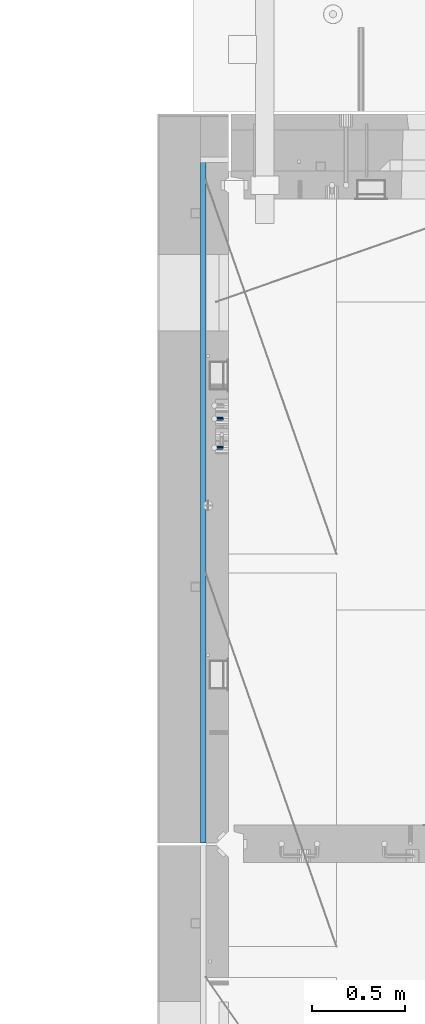
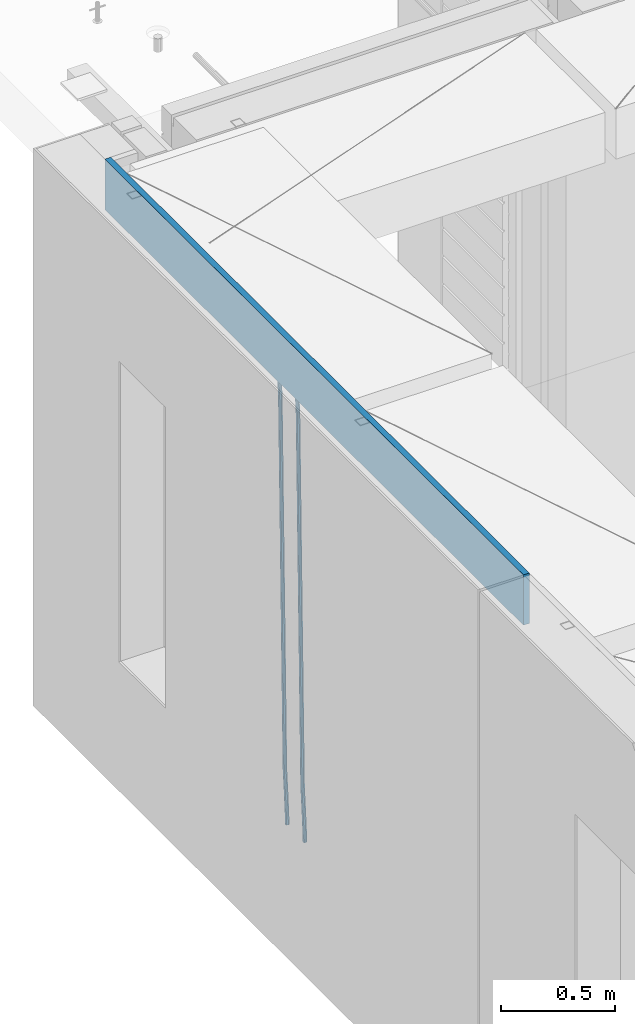
# One storey, part 96 of 309: 3 beams, 1 element without a shape of its own.
"""IFC2X3 building model written with IfcOpenShell, lengths in millimetres."""

from ifc_helpers import new_model, si_unit, frame, origin_with_axes, place, context, subcontext, project, spatial, faceted_brep, material, type_object, element, aggregate, save


model = new_model("IFC2X3")

# Units and contexts
model_context = context("Model", 3, precision=1e-05, world=origin_with_axes())
body_context = subcontext(model_context, "Body", "Model", "MODEL_VIEW")
ifc_project = project(units=[si_unit("LENGTHUNIT", "METRE", prefix="MILLI"), si_unit("AREAUNIT", "SQUARE_METRE"), si_unit("VOLUMEUNIT", "CUBIC_METRE"), si_unit("MASSUNIT", "GRAM", prefix="KILO"), si_unit("TIMEUNIT", "SECOND"), si_unit("PLANEANGLEUNIT", "RADIAN"), si_unit("SOLIDANGLEUNIT", "STERADIAN"), si_unit("THERMODYNAMICTEMPERATUREUNIT", "DEGREE_CELSIUS"), si_unit("LUMINOUSINTENSITYUNIT", "LUMEN")], contexts=[model_context])

# Site, building, storey
site_placement = place(None, origin_with_axes())
site = spatial("IfcSite", under=ifc_project, at=site_placement, CompositionType="ELEMENT")
building_placement = place(site_placement, origin_with_axes())
building = spatial("IfcBuilding", under=site, at=building_placement, CompositionType="ELEMENT")
storey_placement = place(building_placement, origin_with_axes())
storey = spatial("IfcBuildingStorey", under=building, at=storey_placement, Name="7", CompositionType="ELEMENT", Elevation=0.0)

# Assembly, beams
assembly_placement = place(storey_placement, origin_with_axes())
assembly = element("IfcElementAssembly", 1, at=assembly_placement, inside=storey, AssemblyPlace="NOTDEFINED", PredefinedType="REINFORCEMENT_UNIT")
ifc_material_1 = material()
beam_type_1 = type_object("IfcBeamType", Name="D20", PredefinedType="NOTDEFINED")
beam_1_placement = place(assembly_placement, frame((7965.00000455602, 19100.0000000039, 99990.0), z_axis=(-0.999642804636942, -0.000205726999925762, -0.0267249099902983), x_axis=(-0.0267249099948371, 4.30000201934385e-08, 0.999642825806181)))
beam_1 = element("IfcBeam", 2, at=beam_1_placement, type_object=beam_type_1, material=ifc_material_1, Name="JM20", ObjectType="D20", context=body_context, shape_type="Brep", body=[
    faceted_brep([(0.0, -10.0, 0.0), (-4.19531716033816e-08, -7.07106781186667, -7.07106781187031), (60.4266690400545, -7.0710677960451, -7.07106780570757), (60.4266690441291, -9.99999998418934, 6.15546014159918e-09), (0.0, 0.0, -10.0), (60.426669036824, 1.58106558956206e-08, -9.99999999384454), (4.196772351861e-08, 7.07106781186303, -7.07106781186667), (60.4266690363438, 7.07106782768096, -7.07106780570757), (0.0, 10.0, 0.0), (60.4266690388904, 10.0000000158179, 6.15182216279209e-09), (4.196772351861e-08, 7.07106781185939, 7.07106781185939), (60.4266690429649, 7.07106782768096, 7.07106781802577), (0.0, 0.0, 10.0), (60.4266690461809, 1.58179318532348e-08, 10.0000000061555), (-4.19531716033816e-08, -7.07106781187031, 7.07106781185939), (60.4266690466611, -7.07106779605238, 7.07106781802213), (61.0378400410118, -7.07106779588503, -7.07106780564936), (60.991799419251, -9.99999998403655, 6.21366780251265e-09), (61.0569027789461, 1.5985278878361e-08, -9.99999999378269), (61.0378209396877, 7.07106782784831, -7.07106780564936), (60.9917724058905, 10.0000000159635, 6.21366780251265e-09), (60.9457317841297, 7.07106782781193, 7.0710678180767), (60.9266690461809, 1.59488990902901e-08, 10.0000000062028), (60.9457508854539, -7.07106779591413, 7.0710678180767), (61.6489592143771, -7.07106614513759, -7.06310863441468), (61.5568818710308, -9.9999984576425, 0.00735959856683621), (61.6870830769039, 1.71821739058942e-06, -9.99179257185824), (61.6489210170112, 7.07106947854481, -7.06310888312146), (61.556827851804, 10.0000015422847, 0.00735924683976918), (61.4647505084577, 7.07106922979438, 7.07782747982128), (61.4266266459163, 1.36643211590126e-06, 10.0065114172685), (61.464788705809, -7.07106639389531, 7.07782772852806), (176.543135720174, -7.07075579406956, -5.56673531796696), (176.451058376813, -9.99968810657447, 1.50373291501455), (176.581259582701, 0.000312069292704109, -8.49541925541052), (176.543097522794, 7.07137982961285, -5.56673556667374), (176.451004357587, 10.00031189336, 1.50373256329476), (176.35892701424, 7.07137958085514, 8.57420079627263), (176.320803151699, 0.000311717507429421, 11.5028847337162), (176.358965211621, -7.07075604281999, 8.57420104497578), (177.098753836006, -7.07075429323595, -5.55949898843028), (176.98362511232, -9.99968666800123, 1.510669025065), (177.146421932586, 0.000313595905026887, -8.48805862247536), (177.098706077581, 7.07138133041735, -5.55949936166144), (176.983557571715, 10.0003133318824, 1.51066849724157), (176.868428848029, 7.07138095712435, 8.58083651073321), (176.820760751449, 0.000313067976094317, 11.5093961447819), (176.868476606425, -7.07075466652896, 8.58083688396073), (177.654312950661, -7.07075204110879, -5.54863964998367), (177.516135294456, -9.99968450931192, 1.52107783331303), (177.711524267797, 0.000315886711177882, -8.47701274570863), (177.654255632195, 7.07138358250813, -5.54864021007961), (177.516054233929, 10.0003154905207, 1.5210770412159), (177.377876577739, 7.0713830223176, 8.59079452451624), (177.320665260588, 0.000315094497636892, 11.5191676202448), (177.377933896176, -7.07075260129932, 8.59079508461218), (299.436796249574, -7.07025836271714, -3.1681962331204), (299.298618593355, -9.99919083092027, 3.90152125031091), (299.494007566798, 0.000809565110102994, -6.09656932889993), (299.436738931283, 7.07187726089978, -3.16819679320906), (299.298537533061, 10.0008091689197, 3.90152045822106), (299.160359876842, 7.07187670072017, 10.9712379416487), (299.103148559603, 0.000808772889286047, 13.8996110374392), (299.160417195119, -7.07025892290039, 10.9712385017483), (299.98743051647, -7.07025613056248, -3.15743315966392), (299.971788958996, -9.99918809853989, 3.91467979818117), (299.993912075952, 0.000811591617093654, -6.08679785393178), (299.987423933868, 7.07187949325817, -3.1574327280432), (299.971753863239, 10.0008119014747, 3.91467990454839), (299.95611230444, 7.07187992653053, 10.9867922621015), (299.949630744944, 0.000812204350950196, 13.9161569563694), (299.956118887014, -7.07025569729012, 10.9867918304735), (300.538107039494, -7.07025785017686, -3.16575821840888), (300.644985195438, -9.99919020432935, 3.90450175465594), (300.493854948218, 0.000810030429420294, -6.09435592770024), (300.538151196495, 7.071877773491, -3.16575855385963), (300.645047642858, 10.0008097955724, 3.90450128024895), (300.751925798773, 7.07187744142357, 10.9747612533101), (300.796177890064, 0.000809560813650023, 13.9033589625978), (300.751881641787, -7.07025818224065, 10.9747615887682), (2293.36490490142, -7.07648090940347, -33.2930642912361), (2293.47178305736, -10.0054132635523, -26.2228043181785), (2293.32065281013, -0.00541302880083094, -36.2216620005347), (2293.36494905842, 7.06565471425711, -33.2930646266868), (2293.47184550477, 9.99458673634581, -26.2228047925819), (2293.57872366071, 7.06565438219332, -19.1525448195243), (2293.62297575199, -0.00541349841296324, -16.2239471102366), (2293.57867950371, -7.0764812414709, -19.1525444840736), (2294.0658245362, -7.07648309818615, -33.3036607065333), (2294.05312277409, -10.0054150789219, -26.2315929392535), (2294.10928714235, -0.00541549149056664, -36.2335844756526), (2294.15805078732, 7.06565223761572, -33.3050546393533), (2294.18355038921, 9.99458451388637, -26.2335642579346), (2294.17084862708, 7.06565253314329, -19.1614964906439), (2294.12738602093, -0.00541507354500936, -16.2315727215355), (2294.07862237596, -7.07648280265857, -19.1601025578348), (2294.76670261032, -7.08562269121467, -33.294332712383), (2294.63442802057, -10.0129954178956, -26.2238563411993), (2294.89787471293, -0.0156988342423574, -36.2230891548279), (2294.95110548967, 7.05531064255774, -33.2944998654275), (2294.89521307347, 9.98530428734011, -26.2240927312887), (2294.76293848372, 7.0579315606592, -19.1536163601049), (2294.63176638114, -0.0119922963167483, -16.2248599176673), (2294.57853560438, -7.08300177311321, -19.1534492070678), (2316.52657204497, -7.36937582653991, -33.0047303660212), (2316.39429745522, -10.2967485532172, -25.9342539948302), (2316.65774414754, -0.299451969567599, -35.9334868084661), (2316.7109749243, 6.7715575072325, -33.0048975190657), (2316.65508250811, 9.70155115201487, -25.9344903849269), (2316.52280791836, 6.7741784253376, -18.8640140137468), (2316.39163581574, -0.295745431634714, -15.9352575713092), (2316.33840503903, -7.36675490843481, -18.863846860706), (2317.16202064224, -7.37766220584308, -32.9962731735213), (2317.05438744847, -10.3053562613532, -25.9254688497131), (2317.23607125619, -0.306993473008333, -35.925789846493), (2317.23316144495, 6.76474808850253, -32.9979477328052), (2317.15499573652, 9.6950321815566, -25.9278370341635), (2317.04736254275, 6.7673381260538, -18.8570327103698), (2316.97331192881, -0.303330606784584, -15.9275160373909), (2316.97622174003, -7.37507216829545, -18.8553581510787), (2317.79752306276, -7.37578610372293, -32.9880110666527), (2317.71453320107, -10.3033876998124, -25.9168792378296), (2317.81444760226, -0.305295583297266, -35.918287695793), (2317.75539265381, 6.76628640723357, -32.9911928173897), (2317.65495180529, 9.69652304524061, -25.9213789128698), (2317.5719619436, 6.76892144914746, -18.8502470840467), (2317.55503740412, -0.301569071270933, -15.9199704549137), (2317.61409235255, -7.3731510618054, -18.847065333317), (2417.8183084176, -7.07752398473531, -31.6906369377139), (2417.73531855589, -10.0051255808248, -24.6195051088798), (2417.83523295709, -0.007033464313281, -34.6209135668432), (2417.77617800863, 7.06454852621755, -31.6938186884508), (2417.67573716014, 9.99478516423187, -24.6240047839383), (2417.59274729842, 7.06718356813872, -17.5528729551006), (2417.57582275895, -0.00330695228694822, -14.6225963259749), (2417.6348777074, -7.07488894281778, -17.5496912043673)], [[[0, 1, 2, 3]], [[1, 4, 5, 2]], [[4, 6, 7, 5]], [[6, 8, 9, 7]], [[8, 10, 11, 9]], [[10, 12, 13, 11]], [[12, 14, 15, 13]], [[14, 0, 3, 15]], [[14, 12, 10, 8, 6, 4, 1, 0]], [[3, 2, 16, 17]], [[2, 5, 18, 16]], [[5, 7, 19, 18]], [[7, 9, 20, 19]], [[9, 11, 21, 20]], [[11, 13, 22, 21]], [[13, 15, 23, 22]], [[15, 3, 17, 23]], [[17, 16, 24, 25]], [[16, 18, 26, 24]], [[18, 19, 27, 26]], [[19, 20, 28, 27]], [[20, 21, 29, 28]], [[21, 22, 30, 29]], [[22, 23, 31, 30]], [[23, 17, 25, 31]], [[25, 24, 32, 33]], [[24, 26, 34, 32]], [[26, 27, 35, 34]], [[27, 28, 36, 35]], [[28, 29, 37, 36]], [[29, 30, 38, 37]], [[30, 31, 39, 38]], [[31, 25, 33, 39]], [[33, 32, 40, 41]], [[32, 34, 42, 40]], [[34, 35, 43, 42]], [[35, 36, 44, 43]], [[36, 37, 45, 44]], [[37, 38, 46, 45]], [[38, 39, 47, 46]], [[39, 33, 41, 47]], [[41, 40, 48, 49]], [[40, 42, 50, 48]], [[42, 43, 51, 50]], [[43, 44, 52, 51]], [[44, 45, 53, 52]], [[45, 46, 54, 53]], [[46, 47, 55, 54]], [[47, 41, 49, 55]], [[49, 48, 56, 57]], [[48, 50, 58, 56]], [[50, 51, 59, 58]], [[51, 52, 60, 59]], [[52, 53, 61, 60]], [[53, 54, 62, 61]], [[54, 55, 63, 62]], [[55, 49, 57, 63]], [[57, 56, 64, 65]], [[56, 58, 66, 64]], [[58, 59, 67, 66]], [[59, 60, 68, 67]], [[60, 61, 69, 68]], [[61, 62, 70, 69]], [[62, 63, 71, 70]], [[63, 57, 65, 71]], [[65, 64, 72, 73]], [[64, 66, 74, 72]], [[66, 67, 75, 74]], [[67, 68, 76, 75]], [[68, 69, 77, 76]], [[69, 70, 78, 77]], [[70, 71, 79, 78]], [[71, 65, 73, 79]], [[73, 72, 80, 81]], [[72, 74, 82, 80]], [[74, 75, 83, 82]], [[75, 76, 84, 83]], [[76, 77, 85, 84]], [[77, 78, 86, 85]], [[78, 79, 87, 86]], [[79, 73, 81, 87]], [[81, 80, 88, 89]], [[80, 82, 90, 88]], [[82, 83, 91, 90]], [[83, 84, 92, 91]], [[84, 85, 93, 92]], [[85, 86, 94, 93]], [[86, 87, 95, 94]], [[87, 81, 89, 95]], [[89, 88, 96, 97]], [[88, 90, 98, 96]], [[90, 91, 99, 98]], [[91, 92, 100, 99]], [[92, 93, 101, 100]], [[93, 94, 102, 101]], [[94, 95, 103, 102]], [[95, 89, 97, 103]], [[97, 96, 104, 105]], [[96, 98, 106, 104]], [[98, 99, 107, 106]], [[99, 100, 108, 107]], [[100, 101, 109, 108]], [[101, 102, 110, 109]], [[102, 103, 111, 110]], [[103, 97, 105, 111]], [[105, 104, 112, 113]], [[104, 106, 114, 112]], [[106, 107, 115, 114]], [[107, 108, 116, 115]], [[108, 109, 117, 116]], [[109, 110, 118, 117]], [[110, 111, 119, 118]], [[111, 105, 113, 119]], [[113, 112, 120, 121]], [[112, 114, 122, 120]], [[114, 115, 123, 122]], [[115, 116, 124, 123]], [[116, 117, 125, 124]], [[117, 118, 126, 125]], [[118, 119, 127, 126]], [[119, 113, 121, 127]], [[121, 120, 128, 129]], [[120, 122, 130, 128]], [[122, 123, 131, 130]], [[123, 124, 132, 131]], [[124, 125, 133, 132]], [[125, 126, 134, 133]], [[126, 127, 135, 134]], [[127, 121, 129, 135]], [[130, 131, 132, 133, 134, 135, 129, 128]]]),
])
beam_2_placement = place(assembly_placement, frame((7965.00000455602, 19255.0000000039, 99990.0), z_axis=(-0.999642804636942, -0.000205726999925762, -0.0267249099902983), x_axis=(-0.0267249099948371, 4.30000201934385e-08, 0.999642825806181)))
beam_2 = element("IfcBeam", 3, at=beam_2_placement, type_object=beam_type_1, material=ifc_material_1, Name="JM20", ObjectType="D20", context=body_context, shape_type="Brep", body=[
    faceted_brep([(0.0, -10.0, 0.0), (-4.19531716033816e-08, -7.07106781186667, -7.07106781187031), (60.4266690400545, -7.0710677960451, -7.07106780570757), (60.4266690441291, -9.99999998418934, 6.15546014159918e-09), (0.0, 0.0, -10.0), (60.426669036824, 1.58106558956206e-08, -9.99999999384454), (4.196772351861e-08, 7.07106781186303, -7.07106781186667), (60.4266690363438, 7.07106782768096, -7.07106780570757), (0.0, 10.0, 0.0), (60.4266690388904, 10.0000000158179, 6.15182216279209e-09), (4.196772351861e-08, 7.07106781185939, 7.07106781185939), (60.4266690429649, 7.07106782768096, 7.07106781802577), (0.0, 0.0, 10.0), (60.4266690461809, 1.58179318532348e-08, 10.0000000061555), (-4.19531716033816e-08, -7.07106781187031, 7.07106781185939), (60.4266690466611, -7.07106779605238, 7.07106781802213), (61.0378400410118, -7.07106779588503, -7.07106780564936), (60.991799419251, -9.99999998403655, 6.21366780251265e-09), (61.0569027789461, 1.5985278878361e-08, -9.99999999378269), (61.0378209396877, 7.07106782784831, -7.07106780564936), (60.9917724058905, 10.0000000159635, 6.21366780251265e-09), (60.9457317841297, 7.07106782781193, 7.0710678180767), (60.9266690461809, 1.59488990902901e-08, 10.0000000062028), (60.9457508854539, -7.07106779591413, 7.0710678180767), (61.6489592143771, -7.07106614513759, -7.06310863441468), (61.5568818710308, -9.9999984576425, 0.00735959856683621), (61.6870830769039, 1.71821739058942e-06, -9.99179257185824), (61.6489210170112, 7.07106947854481, -7.06310888312146), (61.556827851804, 10.0000015422847, 0.00735924683976918), (61.4647505084577, 7.07106922979438, 7.07782747982128), (61.4266266459163, 1.36643211590126e-06, 10.0065114172685), (61.464788705809, -7.07106639389531, 7.07782772852806), (176.543135720174, -7.07075579406956, -5.56673531796696), (176.451058376813, -9.99968810657447, 1.50373291501455), (176.581259582701, 0.000312069292704109, -8.49541925541052), (176.543097522794, 7.07137982961285, -5.56673556667374), (176.451004357587, 10.00031189336, 1.50373256329476), (176.35892701424, 7.07137958085514, 8.57420079627263), (176.320803151699, 0.000311717507429421, 11.5028847337162), (176.358965211621, -7.07075604281999, 8.57420104497578), (177.098753836006, -7.07075429323595, -5.55949898843028), (176.98362511232, -9.99968666800123, 1.510669025065), (177.146421932586, 0.000313595905026887, -8.48805862247536), (177.098706077581, 7.07138133041735, -5.55949936166144), (176.983557571715, 10.0003133318824, 1.51066849724157), (176.868428848029, 7.07138095712435, 8.58083651073321), (176.820760751449, 0.000313067976094317, 11.5093961447819), (176.868476606425, -7.07075466652896, 8.58083688396073), (177.654312950661, -7.07075204110879, -5.54863964998367), (177.516135294456, -9.99968450931192, 1.52107783331303), (177.711524267797, 0.000315886711177882, -8.47701274570863), (177.654255632195, 7.07138358250813, -5.54864021007961), (177.516054233929, 10.0003154905207, 1.5210770412159), (177.377876577739, 7.0713830223176, 8.59079452451624), (177.320665260588, 0.000315094497636892, 11.5191676202448), (177.377933896176, -7.07075260129932, 8.59079508461218), (299.436796249574, -7.07025836271714, -3.1681962331204), (299.298618593355, -9.99919083092027, 3.90152125031091), (299.494007566798, 0.000809565110102994, -6.09656932889993), (299.436738931283, 7.07187726089978, -3.16819679320906), (299.298537533061, 10.0008091689197, 3.90152045822106), (299.160359876842, 7.07187670072017, 10.9712379416487), (299.103148559603, 0.000808772889286047, 13.8996110374392), (299.160417195119, -7.07025892290039, 10.9712385017483), (299.98743051647, -7.07025613056248, -3.15743315966392), (299.971788958996, -9.99918809853989, 3.91467979818117), (299.993912075952, 0.000811591617093654, -6.08679785393178), (299.987423933868, 7.07187949325817, -3.1574327280432), (299.971753863239, 10.0008119014747, 3.91467990454839), (299.95611230444, 7.07187992653053, 10.9867922621015), (299.949630744944, 0.000812204350950196, 13.9161569563694), (299.956118887014, -7.07025569729012, 10.9867918304735), (300.538107039494, -7.07025785017686, -3.16575821840888), (300.644985195438, -9.99919020432935, 3.90450175465594), (300.493854948218, 0.000810030429420294, -6.09435592770024), (300.538151196495, 7.071877773491, -3.16575855385963), (300.645047642858, 10.0008097955724, 3.90450128024895), (300.751925798773, 7.07187744142357, 10.9747612533101), (300.796177890064, 0.000809560813650023, 13.9033589625978), (300.751881641787, -7.07025818224065, 10.9747615887682), (2293.36490490142, -7.07648090940347, -33.2930642912361), (2293.47178305736, -10.0054132635523, -26.2228043181785), (2293.32065281013, -0.00541302880083094, -36.2216620005347), (2293.36494905842, 7.06565471425711, -33.2930646266868), (2293.47184550477, 9.99458673634581, -26.2228047925819), (2293.57872366071, 7.06565438219332, -19.1525448195243), (2293.62297575199, -0.00541349841296324, -16.2239471102366), (2293.57867950371, -7.0764812414709, -19.1525444840736), (2294.0658245362, -7.07648309818615, -33.3036607065333), (2294.05312277409, -10.0054150789219, -26.2315929392535), (2294.10928714235, -0.00541549149056664, -36.2335844756526), (2294.15805078732, 7.06565223761572, -33.3050546393533), (2294.18355038921, 9.99458451388637, -26.2335642579346), (2294.17084862708, 7.06565253314329, -19.1614964906439), (2294.12738602093, -0.00541507354500936, -16.2315727215355), (2294.07862237596, -7.07648280265857, -19.1601025578348), (2294.76670261032, -7.08562269121467, -33.294332712383), (2294.63442802057, -10.0129954178956, -26.2238563411993), (2294.89787471293, -0.0156988342423574, -36.2230891548279), (2294.95110548967, 7.05531064255774, -33.2944998654275), (2294.89521307347, 9.98530428734011, -26.2240927312887), (2294.76293848372, 7.0579315606592, -19.1536163601049), (2294.63176638114, -0.0119922963167483, -16.2248599176673), (2294.57853560438, -7.08300177311321, -19.1534492070678), (2316.52657204497, -7.36937582653991, -33.0047303660212), (2316.39429745522, -10.2967485532172, -25.9342539948302), (2316.65774414754, -0.299451969567599, -35.9334868084661), (2316.7109749243, 6.7715575072325, -33.0048975190657), (2316.65508250811, 9.70155115201487, -25.9344903849269), (2316.52280791836, 6.7741784253376, -18.8640140137468), (2316.39163581574, -0.295745431634714, -15.9352575713092), (2316.33840503903, -7.36675490843481, -18.863846860706), (2317.16202064224, -7.37766220584308, -32.9962731735213), (2317.05438744847, -10.3053562613532, -25.9254688497131), (2317.23607125619, -0.306993473008333, -35.925789846493), (2317.23316144495, 6.76474808850253, -32.9979477328052), (2317.15499573652, 9.6950321815566, -25.9278370341635), (2317.04736254275, 6.7673381260538, -18.8570327103698), (2316.97331192881, -0.303330606784584, -15.9275160373909), (2316.97622174003, -7.37507216829545, -18.8553581510787), (2317.79752306276, -7.37578610372293, -32.9880110666527), (2317.71453320107, -10.3033876998124, -25.9168792378296), (2317.81444760226, -0.305295583297266, -35.918287695793), (2317.75539265381, 6.76628640723357, -32.9911928173897), (2317.65495180529, 9.69652304524061, -25.9213789128698), (2317.5719619436, 6.76892144914746, -18.8502470840467), (2317.55503740412, -0.301569071270933, -15.9199704549137), (2317.61409235255, -7.3731510618054, -18.847065333317), (2417.8183084176, -7.07752398473531, -31.6906369377139), (2417.73531855589, -10.0051255808248, -24.6195051088798), (2417.83523295709, -0.007033464313281, -34.6209135668432), (2417.77617800863, 7.06454852621755, -31.6938186884508), (2417.67573716014, 9.99478516423187, -24.6240047839383), (2417.59274729842, 7.06718356813872, -17.5528729551006), (2417.57582275895, -0.00330695228694822, -14.6225963259749), (2417.6348777074, -7.07488894281778, -17.5496912043673)], [[[0, 1, 2, 3]], [[1, 4, 5, 2]], [[4, 6, 7, 5]], [[6, 8, 9, 7]], [[8, 10, 11, 9]], [[10, 12, 13, 11]], [[12, 14, 15, 13]], [[14, 0, 3, 15]], [[14, 12, 10, 8, 6, 4, 1, 0]], [[3, 2, 16, 17]], [[2, 5, 18, 16]], [[5, 7, 19, 18]], [[7, 9, 20, 19]], [[9, 11, 21, 20]], [[11, 13, 22, 21]], [[13, 15, 23, 22]], [[15, 3, 17, 23]], [[17, 16, 24, 25]], [[16, 18, 26, 24]], [[18, 19, 27, 26]], [[19, 20, 28, 27]], [[20, 21, 29, 28]], [[21, 22, 30, 29]], [[22, 23, 31, 30]], [[23, 17, 25, 31]], [[25, 24, 32, 33]], [[24, 26, 34, 32]], [[26, 27, 35, 34]], [[27, 28, 36, 35]], [[28, 29, 37, 36]], [[29, 30, 38, 37]], [[30, 31, 39, 38]], [[31, 25, 33, 39]], [[33, 32, 40, 41]], [[32, 34, 42, 40]], [[34, 35, 43, 42]], [[35, 36, 44, 43]], [[36, 37, 45, 44]], [[37, 38, 46, 45]], [[38, 39, 47, 46]], [[39, 33, 41, 47]], [[41, 40, 48, 49]], [[40, 42, 50, 48]], [[42, 43, 51, 50]], [[43, 44, 52, 51]], [[44, 45, 53, 52]], [[45, 46, 54, 53]], [[46, 47, 55, 54]], [[47, 41, 49, 55]], [[49, 48, 56, 57]], [[48, 50, 58, 56]], [[50, 51, 59, 58]], [[51, 52, 60, 59]], [[52, 53, 61, 60]], [[53, 54, 62, 61]], [[54, 55, 63, 62]], [[55, 49, 57, 63]], [[57, 56, 64, 65]], [[56, 58, 66, 64]], [[58, 59, 67, 66]], [[59, 60, 68, 67]], [[60, 61, 69, 68]], [[61, 62, 70, 69]], [[62, 63, 71, 70]], [[63, 57, 65, 71]], [[65, 64, 72, 73]], [[64, 66, 74, 72]], [[66, 67, 75, 74]], [[67, 68, 76, 75]], [[68, 69, 77, 76]], [[69, 70, 78, 77]], [[70, 71, 79, 78]], [[71, 65, 73, 79]], [[73, 72, 80, 81]], [[72, 74, 82, 80]], [[74, 75, 83, 82]], [[75, 76, 84, 83]], [[76, 77, 85, 84]], [[77, 78, 86, 85]], [[78, 79, 87, 86]], [[79, 73, 81, 87]], [[81, 80, 88, 89]], [[80, 82, 90, 88]], [[82, 83, 91, 90]], [[83, 84, 92, 91]], [[84, 85, 93, 92]], [[85, 86, 94, 93]], [[86, 87, 95, 94]], [[87, 81, 89, 95]], [[89, 88, 96, 97]], [[88, 90, 98, 96]], [[90, 91, 99, 98]], [[91, 92, 100, 99]], [[92, 93, 101, 100]], [[93, 94, 102, 101]], [[94, 95, 103, 102]], [[95, 89, 97, 103]], [[97, 96, 104, 105]], [[96, 98, 106, 104]], [[98, 99, 107, 106]], [[99, 100, 108, 107]], [[100, 101, 109, 108]], [[101, 102, 110, 109]], [[102, 103, 111, 110]], [[103, 97, 105, 111]], [[105, 104, 112, 113]], [[104, 106, 114, 112]], [[106, 107, 115, 114]], [[107, 108, 116, 115]], [[108, 109, 117, 116]], [[109, 110, 118, 117]], [[110, 111, 119, 118]], [[111, 105, 113, 119]], [[113, 112, 120, 121]], [[112, 114, 122, 120]], [[114, 115, 123, 122]], [[115, 116, 124, 123]], [[116, 117, 125, 124]], [[117, 118, 126, 125]], [[118, 119, 127, 126]], [[119, 113, 121, 127]], [[121, 120, 128, 129]], [[120, 122, 130, 128]], [[122, 123, 131, 130]], [[123, 124, 132, 131]], [[124, 125, 133, 132]], [[125, 126, 134, 133]], [[126, 127, 135, 134]], [[127, 121, 129, 135]], [[130, 131, 132, 133, 134, 135, 129, 128]]]),
])
ifc_material_2 = material(Name="CONCRETE/C25/30")
beam_type_2 = type_object("IfcBeamType", Name="270X30", PredefinedType="NOTDEFINED")
beam_3_placement = place(assembly_placement, frame((7865.0, 20654.9951872276, 102605.0), z_axis=(0.0, 0.0, 1.0), x_axis=(0.0, -1.0, 0.0)))
beam_3 = element("IfcBeam", 4, at=beam_3_placement, type_object=beam_type_2, material=ifc_material_2, ObjectType="270X30", context=body_context, shape_type="Brep", body=[
    faceted_brep([(0.0, 15.0, -135.0), (0.0, 15.0, 135.0), (3669.99518722759, 15.0, 135.0), (3669.99518722759, 15.0, -135.0), (0.0, -15.0, 135.0), (3669.99518722759, -15.0, 135.0), (0.0, -15.0, -135.0), (3669.99518722759, -15.0, -135.0)], [[[0, 1, 2, 3]], [[1, 4, 5, 2]], [[4, 6, 7, 5]], [[6, 0, 3, 7]], [[5, 7, 3, 2]], [[6, 4, 1, 0]]]),
])
aggregate(assembly, [beam_1, beam_2, beam_3])

save(model, "model.ifc")
